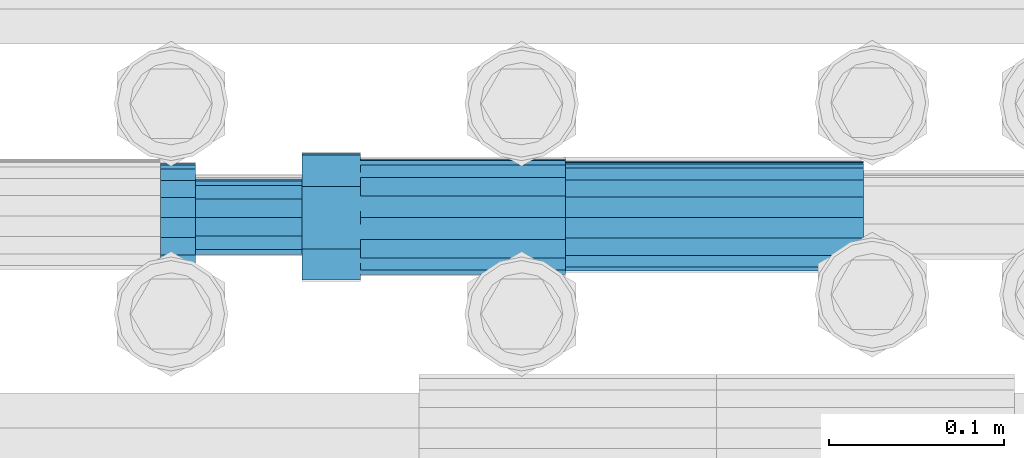
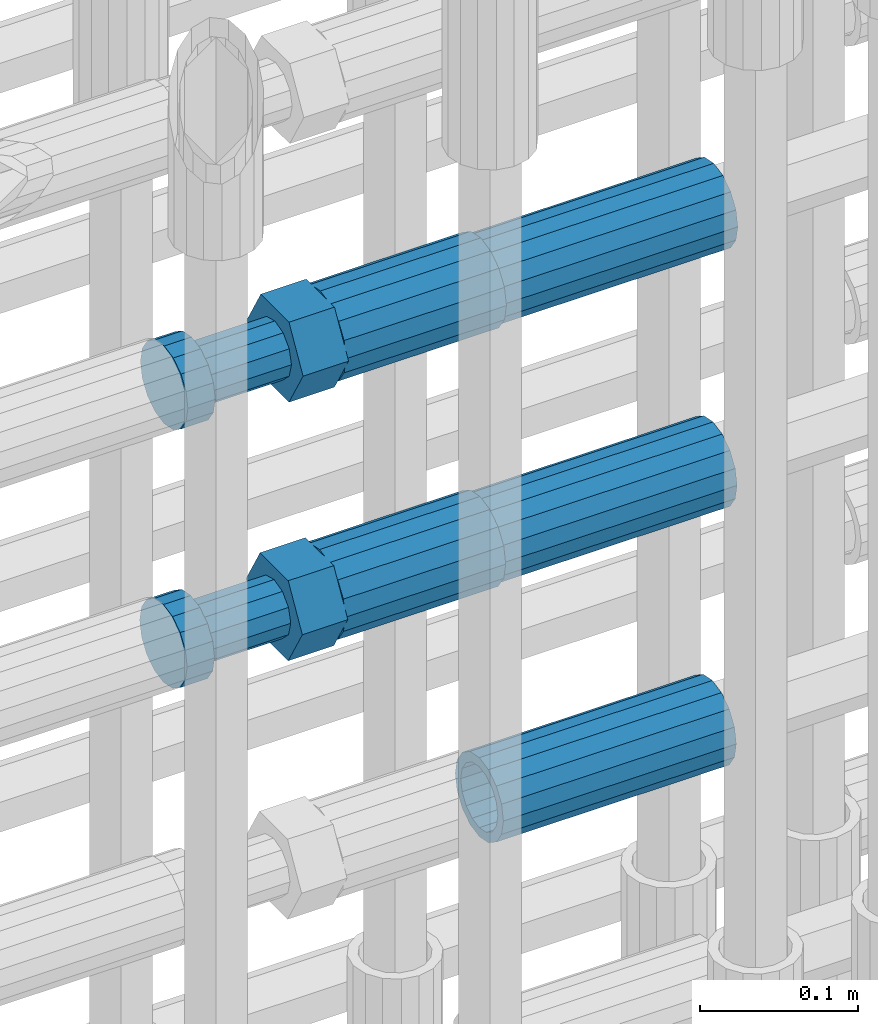
# One storey, part 41 of 119: 5 beams.
"""IFC2X3 building model written with IfcOpenShell, lengths in millimetres."""

from ifc_helpers import new_model, si_unit, frame, origin_with_axes, place, context, subcontext, project, spatial, faceted_brep, material, type_object, element, save


model = new_model("IFC2X3")

# Units and contexts
model_context = context("Model", 3, precision=1e-05, world=origin_with_axes())
body_context = subcontext(model_context, "Body", "Model", "MODEL_VIEW")
ifc_project = project(units=[si_unit("LENGTHUNIT", "METRE", prefix="MILLI"), si_unit("AREAUNIT", "SQUARE_METRE"), si_unit("VOLUMEUNIT", "CUBIC_METRE"), si_unit("MASSUNIT", "GRAM", prefix="KILO"), si_unit("TIMEUNIT", "SECOND"), si_unit("PLANEANGLEUNIT", "RADIAN"), si_unit("SOLIDANGLEUNIT", "STERADIAN"), si_unit("THERMODYNAMICTEMPERATUREUNIT", "DEGREE_CELSIUS"), si_unit("LUMINOUSINTENSITYUNIT", "LUMEN")], contexts=[model_context])

# Site, building, storey
site_placement = place(None, origin_with_axes())
site = spatial("IfcSite", under=ifc_project, at=site_placement, CompositionType="ELEMENT")
building_placement = place(site_placement, origin_with_axes())
building = spatial("IfcBuilding", under=site, at=building_placement, Name="Undefined", CompositionType="ELEMENT")
storey_placement = place(building_placement, origin_with_axes())
storey = spatial("IfcBuildingStorey", under=building, at=storey_placement, Name="Undefined", CompositionType="ELEMENT", Elevation=0.0)

# Beams
ifc_material = material(Name="STEEL/S275")
beam_type_1 = type_object("IfcBeamType", PredefinedType="NOTDEFINED")
beam_1_placement = place(storey_placement, frame((2035519.99345925, 6206280.97777132, 20556.4668409387), z_axis=(0.0, 0.0, 1.0), x_axis=(-0.99999999999998, 1.98000110685822e-07, 0.0)))
element("IfcBeam", 1, at=beam_1_placement, inside=storey, type_object=beam_type_1, material=ifc_material, Name="AG40N", context=body_context, shape_type="Brep", body=[
    faceted_brep([(1.62981450557709e-09, -23.4999999990687, 0.0), (7.45058059692383e-09, -21.7111690142192, 8.99306066057534), (170.000002125278, -21.711168999318, 8.99306066022245), (170.000002127141, -23.4999999844003, -3.66071617463604e-10), (4.65661287307739e-09, -16.6170093587134, 16.6170093578889), (170.000002122484, -16.6170093440451, 16.6170093575288), (1.86264514923096e-09, -8.99306066217832, 21.7111690140277), (170.000002118759, -8.99306064750999, 21.7111690136603), (2.3283064365387e-10, 9.31322574615479e-10, 23.5), (170.000002114102, 1.28056854009628e-08, 23.4999999996485), (-6.51925802230835e-09, 8.99306065868586, 21.7111690140241), (170.00000211224, 8.99306067335419, 21.7111690136639), (-7.45058059692383e-09, 16.6170093561523, 16.6170093578853), (170.000002109446, 16.6170093708206, 16.6170093575324), (-9.31322574615479e-09, 21.711169013055, 8.99306066057534), (170.000002108514, 21.7111690277234, 8.99306066022245), (-1.16415321826935e-09, 23.5000000009313, 0.0), (170.000002108514, 23.5000000144355, -3.66071617463604e-10), (-8.38190317153931e-09, 21.7111690151505, -8.99306066059444), (170.000002110377, 21.7111690300517, -8.9930606609546), (-5.58793544769287e-09, 16.6170093598776, -16.6170093579008), (170.000002113171, 16.6170093745459, -16.6170093582609), (-9.31322574615479e-10, 8.99306066334248, -21.7111690140396), (170.000002115965, 8.99306067801081, -21.7111690143961), (2.3283064365387e-10, 9.31322574615479e-10, -23.5), (170.00000211969, 1.7927959561348e-08, -23.5000000003843), (5.58793544769287e-09, -8.99306065752171, -21.7111690140396), (170.000002123415, -8.99306064285338, -21.7111690143961), (8.38190317153931e-09, -16.6170093549881, -16.6170093579008), (170.000002125278, -16.6170093403198, -16.6170093582646), (9.31322574615479e-09, -21.7111690121237, -8.99306066059444), (170.000002127141, -21.7111689972226, -8.9930606609546), (1.11758708953857e-08, -30.4999999990687, -9.54969436861575e-12), (1.30385160446167e-08, -28.1783257392235, -11.6718446871514), (170.000002129003, -28.1783257243223, -11.6718446875116), (170.000002129935, -30.4999999841675, -3.66071617463604e-10), (1.02445483207703e-08, -21.5667568228673, -21.5667568262129), (170.000002128072, -21.566756808199, -21.5667568265694), (7.45058059692383e-09, -11.6718446831219, -28.1783257416196), (170.000002125278, -11.6718446684536, -28.1783257419834), (3.72529029846191e-09, 3.95812094211578e-09, -30.5000000000277), (170.00000211969, 1.83936208486557e-08, -30.5000000003879), (-9.31322574615479e-10, 11.6718446905725, -28.1783257416232), (170.000002115965, 11.6718447052408, -28.1783257419797), (-6.51925802230835e-09, 21.5667568286881, -21.5667568262093), (170.000002110377, 21.5667568433564, -21.5667568265694), (-9.31322574615479e-09, 28.178325742716, -11.6718446871478), (170.000002108514, 28.1783257573843, -11.6718446875079), (-1.21071934700012e-08, 30.5, -5.91171556152403e-12), (170.000002106652, 30.5000000144355, -3.62433638656512e-10), (-1.21071934700012e-08, 28.1783257401548, 11.6718446871359), (170.00000210572, 28.1783257548232, 11.6718446867794), (-1.02445483207703e-08, 21.5667568240315, 21.5667568261974), (170.000002107583, 21.566756838467, 21.5667568258409), (-7.45058059692383e-09, 11.671844684286, 28.1783257416041), (170.000002110377, 11.6718446989544, 28.178325741244), (-2.79396772384644e-09, -2.56113708019257e-09, 30.5000000000159), (170.000002114102, 1.18743628263474e-08, 30.4999999996558), (1.86264514923096e-09, -11.6718446896411, 28.1783257416114), (170.000002118759, -11.67184467474, 28.178325741244), (7.45058059692383e-09, -21.5667568275239, 21.5667568261974), (170.000002123415, -21.5667568126228, 21.5667568258373), (1.02445483207703e-08, -28.1783257415518, 11.6718446871359), (170.000002127141, -28.1783257271163, 11.6718446867794)], [[[0, 1, 2, 3]], [[1, 4, 5, 2]], [[4, 6, 7, 5]], [[6, 8, 9, 7]], [[8, 10, 11, 9]], [[10, 12, 13, 11]], [[12, 14, 15, 13]], [[14, 16, 17, 15]], [[16, 18, 19, 17]], [[18, 20, 21, 19]], [[20, 22, 23, 21]], [[22, 24, 25, 23]], [[24, 26, 27, 25]], [[26, 28, 29, 27]], [[28, 30, 31, 29]], [[30, 0, 3, 31]], [[32, 33, 34, 35]], [[33, 36, 37, 34]], [[36, 38, 39, 37]], [[38, 40, 41, 39]], [[40, 42, 43, 41]], [[42, 44, 45, 43]], [[44, 46, 47, 45]], [[46, 48, 49, 47]], [[48, 50, 51, 49]], [[50, 52, 53, 51]], [[52, 54, 55, 53]], [[54, 56, 57, 55]], [[56, 58, 59, 57]], [[58, 60, 61, 59]], [[60, 62, 63, 61]], [[62, 32, 35, 63]], [[37, 39, 41, 43, 45, 47, 49, 51, 53, 55, 57, 59, 61, 63, 35, 34], [5, 7, 9, 11, 13, 15, 17, 19, 21, 23, 25, 27, 29, 31, 3, 2]], [[62, 60, 58, 56, 54, 52, 50, 48, 46, 44, 42, 40, 38, 36, 33, 32], [30, 28, 26, 24, 22, 20, 18, 16, 14, 12, 10, 8, 6, 4, 1, 0]]]),
])
beam_2_placement = place(storey_placement, frame((2035519.99345925, 6206281.90777132, 20356.4668409387), z_axis=(0.0, 0.0, 1.0), x_axis=(-0.99999999999998, 1.98000110685822e-07, 0.0)))
element("IfcBeam", 2, at=beam_2_placement, inside=storey, type_object=beam_type_1, material=ifc_material, Name="AG40N", context=body_context, shape_type="Brep", body=[
    faceted_brep([(1.62981450557709e-09, -23.4999999990687, 0.0), (7.45058059692383e-09, -21.7111690142192, 8.99306066057534), (170.000002125278, -21.711168999318, 8.99306066022245), (170.000002127141, -23.4999999844003, -3.66071617463604e-10), (4.65661287307739e-09, -16.6170093587134, 16.6170093578889), (170.000002122484, -16.6170093440451, 16.6170093575288), (1.86264514923096e-09, -8.99306066217832, 21.7111690140277), (170.000002118759, -8.99306064750999, 21.7111690136603), (2.3283064365387e-10, 9.31322574615479e-10, 23.5), (170.000002114102, 1.28056854009628e-08, 23.4999999996485), (-6.51925802230835e-09, 8.99306065868586, 21.7111690140241), (170.00000211224, 8.99306067335419, 21.7111690136639), (-7.45058059692383e-09, 16.6170093561523, 16.6170093578853), (170.000002109446, 16.6170093708206, 16.6170093575324), (-9.31322574615479e-09, 21.711169013055, 8.99306066057534), (170.000002108514, 21.7111690277234, 8.99306066022245), (-1.16415321826935e-09, 23.5000000009313, 0.0), (170.000002108514, 23.5000000144355, -3.66071617463604e-10), (-8.38190317153931e-09, 21.7111690151505, -8.99306066059444), (170.000002110377, 21.7111690300517, -8.9930606609546), (-5.58793544769287e-09, 16.6170093598776, -16.6170093579008), (170.000002113171, 16.6170093745459, -16.6170093582609), (-9.31322574615479e-10, 8.99306066334248, -21.7111690140396), (170.000002115965, 8.99306067801081, -21.7111690143961), (2.3283064365387e-10, 9.31322574615479e-10, -23.5), (170.00000211969, 1.7927959561348e-08, -23.5000000003843), (5.58793544769287e-09, -8.99306065752171, -21.7111690140396), (170.000002123415, -8.99306064285338, -21.7111690143961), (8.38190317153931e-09, -16.6170093549881, -16.6170093579008), (170.000002125278, -16.6170093403198, -16.6170093582646), (9.31322574615479e-09, -21.7111690121237, -8.99306066059444), (170.000002127141, -21.7111689972226, -8.9930606609546), (1.11758708953857e-08, -30.4999999990687, -9.54969436861575e-12), (1.30385160446167e-08, -28.1783257392235, -11.6718446871514), (170.000002129003, -28.1783257243223, -11.6718446875116), (170.000002129935, -30.4999999841675, -3.66071617463604e-10), (1.02445483207703e-08, -21.5667568228673, -21.5667568262129), (170.000002128072, -21.566756808199, -21.5667568265694), (7.45058059692383e-09, -11.6718446831219, -28.1783257416196), (170.000002125278, -11.6718446684536, -28.1783257419834), (3.72529029846191e-09, 3.95812094211578e-09, -30.5000000000277), (170.00000211969, 1.83936208486557e-08, -30.5000000003879), (-9.31322574615479e-10, 11.6718446905725, -28.1783257416232), (170.000002115965, 11.6718447052408, -28.1783257419797), (-6.51925802230835e-09, 21.5667568286881, -21.5667568262093), (170.000002110377, 21.5667568433564, -21.5667568265694), (-9.31322574615479e-09, 28.178325742716, -11.6718446871478), (170.000002108514, 28.1783257573843, -11.6718446875079), (-1.21071934700012e-08, 30.5, -5.91171556152403e-12), (170.000002106652, 30.5000000144355, -3.62433638656512e-10), (-1.21071934700012e-08, 28.1783257401548, 11.6718446871359), (170.00000210572, 28.1783257548232, 11.6718446867794), (-1.02445483207703e-08, 21.5667568240315, 21.5667568261974), (170.000002107583, 21.566756838467, 21.5667568258409), (-7.45058059692383e-09, 11.671844684286, 28.1783257416041), (170.000002110377, 11.6718446989544, 28.178325741244), (-2.79396772384644e-09, -2.56113708019257e-09, 30.5000000000159), (170.000002114102, 1.18743628263474e-08, 30.4999999996558), (1.86264514923096e-09, -11.6718446896411, 28.1783257416114), (170.000002118759, -11.67184467474, 28.178325741244), (7.45058059692383e-09, -21.5667568275239, 21.5667568261974), (170.000002123415, -21.5667568126228, 21.5667568258373), (1.02445483207703e-08, -28.1783257415518, 11.6718446871359), (170.000002127141, -28.1783257271163, 11.6718446867794)], [[[0, 1, 2, 3]], [[1, 4, 5, 2]], [[4, 6, 7, 5]], [[6, 8, 9, 7]], [[8, 10, 11, 9]], [[10, 12, 13, 11]], [[12, 14, 15, 13]], [[14, 16, 17, 15]], [[16, 18, 19, 17]], [[18, 20, 21, 19]], [[20, 22, 23, 21]], [[22, 24, 25, 23]], [[24, 26, 27, 25]], [[26, 28, 29, 27]], [[28, 30, 31, 29]], [[30, 0, 3, 31]], [[32, 33, 34, 35]], [[33, 36, 37, 34]], [[36, 38, 39, 37]], [[38, 40, 41, 39]], [[40, 42, 43, 41]], [[42, 44, 45, 43]], [[44, 46, 47, 45]], [[46, 48, 49, 47]], [[48, 50, 51, 49]], [[50, 52, 53, 51]], [[52, 54, 55, 53]], [[54, 56, 57, 55]], [[56, 58, 59, 57]], [[58, 60, 61, 59]], [[60, 62, 63, 61]], [[62, 32, 35, 63]], [[37, 39, 41, 43, 45, 47, 49, 51, 53, 55, 57, 59, 61, 63, 35, 34], [5, 7, 9, 11, 13, 15, 17, 19, 21, 23, 25, 27, 29, 31, 3, 2]], [[62, 60, 58, 56, 54, 52, 50, 48, 46, 44, 42, 40, 38, 36, 33, 32], [30, 28, 26, 24, 22, 20, 18, 16, 14, 12, 10, 8, 6, 4, 1, 0]]]),
])
beam_3_placement = place(storey_placement, frame((2035519.99345925, 6206282.82777132, 20156.4668409387), z_axis=(0.0, 0.0, 1.0), x_axis=(-0.99999999999998, 1.98000110685822e-07, 0.0)))
element("IfcBeam", 3, at=beam_3_placement, inside=storey, type_object=beam_type_1, material=ifc_material, Name="AG40N", context=body_context, shape_type="Brep", body=[
    faceted_brep([(1.62981450557709e-09, -23.4999999990687, 0.0), (7.45058059692383e-09, -21.7111690142192, 8.99306066057534), (170.000002125278, -21.711168999318, 8.99306066022245), (170.000002127141, -23.4999999844003, -3.66071617463604e-10), (4.65661287307739e-09, -16.6170093587134, 16.6170093578889), (170.000002122484, -16.6170093440451, 16.6170093575288), (1.86264514923096e-09, -8.99306066217832, 21.7111690140277), (170.000002118759, -8.99306064750999, 21.7111690136603), (2.3283064365387e-10, 9.31322574615479e-10, 23.5), (170.000002114102, 1.28056854009628e-08, 23.4999999996485), (-6.51925802230835e-09, 8.99306065868586, 21.7111690140241), (170.00000211224, 8.99306067335419, 21.7111690136639), (-7.45058059692383e-09, 16.6170093561523, 16.6170093578853), (170.000002109446, 16.6170093708206, 16.6170093575324), (-9.31322574615479e-09, 21.711169013055, 8.99306066057534), (170.000002108514, 21.7111690277234, 8.99306066022245), (-1.16415321826935e-09, 23.5000000009313, 0.0), (170.000002108514, 23.5000000144355, -3.66071617463604e-10), (-8.38190317153931e-09, 21.7111690151505, -8.99306066059444), (170.000002110377, 21.7111690300517, -8.9930606609546), (-5.58793544769287e-09, 16.6170093598776, -16.6170093579008), (170.000002113171, 16.6170093745459, -16.6170093582609), (-9.31322574615479e-10, 8.99306066334248, -21.7111690140396), (170.000002115965, 8.99306067801081, -21.7111690143961), (2.3283064365387e-10, 9.31322574615479e-10, -23.5), (170.00000211969, 1.7927959561348e-08, -23.5000000003843), (5.58793544769287e-09, -8.99306065752171, -21.7111690140396), (170.000002123415, -8.99306064285338, -21.7111690143961), (8.38190317153931e-09, -16.6170093549881, -16.6170093579008), (170.000002125278, -16.6170093403198, -16.6170093582646), (9.31322574615479e-09, -21.7111690121237, -8.99306066059444), (170.000002127141, -21.7111689972226, -8.9930606609546), (1.11758708953857e-08, -30.4999999990687, -9.54969436861575e-12), (1.30385160446167e-08, -28.1783257392235, -11.6718446871514), (170.000002129003, -28.1783257243223, -11.6718446875116), (170.000002129935, -30.4999999841675, -3.66071617463604e-10), (1.02445483207703e-08, -21.5667568228673, -21.5667568262129), (170.000002128072, -21.566756808199, -21.5667568265694), (7.45058059692383e-09, -11.6718446831219, -28.1783257416196), (170.000002125278, -11.6718446684536, -28.1783257419834), (3.72529029846191e-09, 3.95812094211578e-09, -30.5000000000277), (170.00000211969, 1.83936208486557e-08, -30.5000000003879), (-9.31322574615479e-10, 11.6718446905725, -28.1783257416232), (170.000002115965, 11.6718447052408, -28.1783257419797), (-6.51925802230835e-09, 21.5667568286881, -21.5667568262093), (170.000002110377, 21.5667568433564, -21.5667568265694), (-9.31322574615479e-09, 28.178325742716, -11.6718446871478), (170.000002108514, 28.1783257573843, -11.6718446875079), (-1.21071934700012e-08, 30.5, -5.91171556152403e-12), (170.000002106652, 30.5000000144355, -3.62433638656512e-10), (-1.21071934700012e-08, 28.1783257401548, 11.6718446871359), (170.00000210572, 28.1783257548232, 11.6718446867794), (-1.02445483207703e-08, 21.5667568240315, 21.5667568261974), (170.000002107583, 21.566756838467, 21.5667568258409), (-7.45058059692383e-09, 11.671844684286, 28.1783257416041), (170.000002110377, 11.6718446989544, 28.178325741244), (-2.79396772384644e-09, -2.56113708019257e-09, 30.5000000000159), (170.000002114102, 1.18743628263474e-08, 30.4999999996558), (1.86264514923096e-09, -11.6718446896411, 28.1783257416114), (170.000002118759, -11.67184467474, 28.178325741244), (7.45058059692383e-09, -21.5667568275239, 21.5667568261974), (170.000002123415, -21.5667568126228, 21.5667568258373), (1.02445483207703e-08, -28.1783257415518, 11.6718446871359), (170.000002127141, -28.1783257271163, 11.6718446867794)], [[[0, 1, 2, 3]], [[1, 4, 5, 2]], [[4, 6, 7, 5]], [[6, 8, 9, 7]], [[8, 10, 11, 9]], [[10, 12, 13, 11]], [[12, 14, 15, 13]], [[14, 16, 17, 15]], [[16, 18, 19, 17]], [[18, 20, 21, 19]], [[20, 22, 23, 21]], [[22, 24, 25, 23]], [[24, 26, 27, 25]], [[26, 28, 29, 27]], [[28, 30, 31, 29]], [[30, 0, 3, 31]], [[32, 33, 34, 35]], [[33, 36, 37, 34]], [[36, 38, 39, 37]], [[38, 40, 41, 39]], [[40, 42, 43, 41]], [[42, 44, 45, 43]], [[44, 46, 47, 45]], [[46, 48, 49, 47]], [[48, 50, 51, 49]], [[50, 52, 53, 51]], [[52, 54, 55, 53]], [[54, 56, 57, 55]], [[56, 58, 59, 57]], [[58, 60, 61, 59]], [[60, 62, 63, 61]], [[62, 32, 35, 63]], [[37, 39, 41, 43, 45, 47, 49, 51, 53, 55, 57, 59, 61, 63, 35, 34], [5, 7, 9, 11, 13, 15, 17, 19, 21, 23, 25, 27, 29, 31, 3, 2]], [[62, 60, 58, 56, 54, 52, 50, 48, 46, 44, 42, 40, 38, 36, 33, 32], [30, 28, 26, 24, 22, 20, 18, 16, 14, 12, 10, 8, 6, 4, 1, 0]]]),
])
beam_type_2 = type_object("IfcBeamType", Name="ROD65", PredefinedType="NOTDEFINED")
beam_4_placement = place(storey_placement, frame((2035349.99345925, 6206280.97777132, 20556.4668409387), z_axis=(0.0, 0.0, 1.0), x_axis=(-0.99999999999998, 1.98000110685822e-07, 0.0)))
element("IfcBeam", 4, at=beam_4_placement, inside=storey, type_object=beam_type_2, material=ifc_material, Name="AGB40", ObjectType="ROD65", context=body_context, shape_type="Brep", body=[
    faceted_brep([(116.999999999069, 17.8249999252148, 30.8738056446964), (116.999999998137, 22.0056957420893, 23.632628078838), (116.999999999069, 12.4372115600854, 30.0260848066173), (116.999999999069, 8.17543111252598, 30.8738056446964), (117.000000000931, -17.8250000746921, 30.8738056446964), (150.200000001118, -17.8250000723638, 30.8738056446964), (150.199999999255, 17.8249999275431, 30.8738056446964), (117.000000000931, -8.17543109622784, 30.8738056446964), (117.000000001863, -22.0056959956419, 23.6326278985034), (117.000000000931, -12.4372115437873, 30.0260848066173), (117.000000001863, -35.6500000746455, -2.18278728425503e-10), (150.200000002049, -35.6500000723172, -2.18278728425503e-10), (117.000000001863, -30.8443149488885, 8.32369080289209), (117.000000001863, -30.8443149488885, -8.32369080355784), (117.000000002794, -32.4999999918509, 0.0), (117.000000000931, -17.8250000746921, -30.873805645133), (150.200000001118, -17.8250000723638, -30.873805645133), (117.000000001863, -22.0056959961075, -23.6326278982269), (117.000000000931, -8.17543109389953, -30.873805645133), (117.000000000931, -12.4372115437873, -30.0260848066173), (116.999999999069, 17.8249999252148, -30.873805645133), (150.199999999255, 17.8249999275431, -30.873805645133), (116.999999999069, 8.17543111019768, -30.873805645133), (116.999999999069, 12.4372115600854, -30.0260848066173), (116.999999998137, 22.005695742555, -23.6326280785652), (116.999999998137, 35.6499999251682, -2.18278728425503e-10), (150.199999998324, 35.6499999277294, -2.18278728425503e-10), (116.999999998137, 30.8443150522653, -8.32369036550881), (116.999999997206, 32.5000000081491, 0.0), (116.999999998137, 30.8443150522653, 8.32369036483942), (1.86264514923096e-09, -22.9809703885112, 22.9809703885621), (1.86264514923096e-09, -30.0260848065373, 12.4372115518672), (117.000000001863, -30.0260847983882, 12.4372115518672), (117.000000001863, -22.9809703803621, 22.9809703885621), (-1.86264514923096e-09, 22.9809703885112, -22.9809703885621), (-1.86264514923096e-09, 30.0260848065373, -12.4372115518672), (116.999999998137, 30.0260848146863, -12.4372115518672), (116.999999998137, 22.9809703966603, -22.9809703885621), (1.86264514923096e-09, -30.0260848065373, -12.4372115518672), (1.86264514923096e-09, -22.9809703885112, -22.9809703885621), (117.000000001863, -22.9809703803621, -22.9809703885621), (117.000000001863, -30.0260847983882, -12.4372115518672), (9.31322574615479e-10, -12.4372115519363, 30.0260848066173), (0.0, 0.0, 32.5), (-9.31322574615479e-10, 12.4372115519363, 30.0260848066173), (-1.86264514923096e-09, 22.9809703885112, 22.9809703885621), (-1.86264514923096e-09, 30.0260848065373, 12.4372115518672), (-2.79396772384644e-09, 32.5, 0.0), (-9.31322574615479e-10, 12.4372115519363, -30.0260848066173), (0.0, 0.0, -32.5), (9.31322574615479e-10, -12.4372115519363, -30.0260848066173), (2.79396772384644e-09, -32.5, 0.0), (116.999999998137, 22.9809703966603, 22.9809703885621), (116.999999998137, 30.0260848146863, 12.4372115518672), (117.0, 8.14907252788544e-09, -32.5), (117.0, 8.14907252788544e-09, 32.5), (150.200000000186, -10.5000000959262, 18.1865334791873), (150.199999999255, -9.59262251853943e-08, 20.9999999997126), (150.199999998324, 10.4999999040738, 18.1865334791873), (150.199999997392, 18.1865333835594, 10.4999999997126), (150.199999997392, 20.9999999040738, -2.87400325760245e-10), (150.199999997392, 18.1865333835594, -10.5000000002874), (150.199999998324, 10.4999999040738, -18.1865334797621), (150.199999999255, -9.59262251853943e-08, -21.0000000002874), (150.200000000186, -10.5000000959262, -18.1865334797621), (150.200000000186, -18.1865335754119, -10.5000000002874), (150.200000001118, -21.0000000959262, -2.87400325760245e-10), (150.200000000186, -18.1865335754119, 10.4999999997126), (210.979999999516, 10.4999999082647, 18.1865334791873), (210.979999999516, -9.17352735996246e-08, 20.9999999997126), (210.979999997653, 18.1865333877504, 10.4999999997126), (210.979999997653, 20.9999999082647, -2.87400325760245e-10), (210.979999997653, 18.1865333877504, -10.5000000002874), (210.979999999516, 10.4999999082647, -18.1865334797621), (210.979999999516, -9.17352735996246e-08, -21.0000000002874), (210.979999999516, -10.5000000917353, -18.1865334797621), (210.980000000447, -18.1865335712209, -10.5000000002874), (210.980000001378, -21.0000000917353, -2.87400325760245e-10), (210.980000000447, -18.1865335712209, 10.4999999997126), (210.979999999516, -10.5000000917353, 18.1865334791873), (211.001368402503, -27.7269939335529, -11.4911163272045), (211.003082515672, -21.2238095656503, -21.2238154190527), (231.002518340945, -21.2131946226582, -21.2132004554769), (231.000804228708, -27.7163789905608, -11.4805013636287), (211.001368415542, -11.4911086384673, -27.7269970399575), (231.000804241747, -11.4804936954752, -27.7163820763781), (210.996487061493, -0.0106066407170147, -30.0106107396168), (230.995922887698, 8.30227509140968e-06, -29.999995776041), (210.98918159306, 11.4698940692469, -27.7269970332745), (230.988617419265, 11.4805090120062, -27.7163820696951), (210.980564201251, 21.2025913291145, -21.2238154067054), (230.980000027455, 21.2132062721066, -21.2132004431296), (210.971946807578, 27.7057702087332, -11.4911163110701), (230.971382633783, 27.7163851517253, -11.4805013474943), (210.964641331695, 29.9893806746695, -0.0106149565435771), (230.9640771579, 29.9999956176616, 7.03221303410828e-09), (210.959759964608, 27.7057637346443, 11.4698863966551), (230.959195790812, 27.7163786776364, 11.4805013602345), (210.958045851439, 21.2025793667417, 21.2025854885032), (230.957481677644, 21.2131943097338, 21.2132004520827), (210.959759951569, 11.4698784395587, 27.705767109408), (230.959195776843, 11.4804933823179, 27.7163820729838), (210.964641305618, -0.0106235581915826, 29.9893808090674), (230.964077131823, -8.61519947648048e-06, 29.9999957726432), (210.971946774051, -11.4911242681555, 27.7057671027251), (230.971382599324, -11.4805093251634, 27.7163820663009), (210.98056416586, -21.2238215280231, 21.2025854761559), (230.979999991134, -21.2132065852638, 21.2132004397354), (210.989181559533, -27.7270004076418, 11.4698863805206), (230.988617384806, -27.7163854646496, 11.4805013441), (210.996487035416, -30.0106108735781, -0.0106149740058754), (230.995922861621, -29.999995930586, -1.04300852399319e-08)], [[[0, 1, 2, 3]], [[4, 5, 6, 0, 3, 7]], [[8, 4, 7, 9]], [[10, 11, 5, 4, 8, 12]], [[13, 10, 12, 14]], [[15, 16, 11, 10, 13, 17]], [[18, 15, 17, 19]], [[20, 21, 16, 15, 18, 22]], [[20, 22, 23, 24]], [[25, 26, 21, 20, 24, 27]], [[25, 27, 28, 29]], [[30, 31, 32, 33]], [[34, 35, 36, 37]], [[38, 39, 40, 41]], [[31, 30, 42, 43, 44, 45, 46, 47, 35, 34, 48, 49, 50, 39, 38, 51]], [[46, 45, 52, 53]], [[28, 47, 46, 53, 29]], [[27, 36, 35, 47, 28]], [[24, 37, 36, 27]], [[23, 48, 34, 37, 24]], [[22, 54, 49, 48, 23]], [[18, 54, 22]], [[19, 50, 49, 54, 18]], [[17, 40, 39, 50, 19]], [[13, 41, 40, 17]], [[14, 51, 38, 41, 13]], [[12, 32, 31, 51, 14]], [[8, 33, 32, 12]], [[9, 42, 30, 33, 8]], [[7, 55, 43, 42, 9]], [[3, 55, 7]], [[2, 44, 43, 55, 3]], [[1, 52, 45, 44, 2]], [[29, 53, 52, 1]], [[0, 6, 26, 25, 29, 1]], [[5, 11, 16, 21, 26, 6], [56, 57, 58, 59, 60, 61, 62, 63, 64, 65, 66, 67]], [[68, 58, 57, 69]], [[70, 59, 58, 68]], [[71, 60, 59, 70]], [[72, 61, 60, 71]], [[73, 62, 61, 72]], [[74, 63, 62, 73]], [[75, 64, 63, 74]], [[76, 65, 64, 75]], [[77, 66, 65, 76]], [[78, 67, 66, 77]], [[79, 56, 67, 78]], [[69, 57, 56, 79]], [[80, 81, 82, 83]], [[81, 84, 85, 82]], [[84, 86, 87, 85]], [[86, 88, 89, 87]], [[88, 90, 91, 89]], [[90, 92, 93, 91]], [[92, 94, 95, 93]], [[94, 96, 97, 95]], [[96, 98, 99, 97]], [[98, 100, 101, 99]], [[100, 102, 103, 101]], [[102, 104, 105, 103]], [[104, 106, 107, 105]], [[106, 108, 109, 107]], [[108, 110, 111, 109]], [[82, 85, 87, 89, 91, 93, 95, 97, 99, 101, 103, 105, 107, 109, 111, 83]], [[110, 80, 83, 111]], [[108, 106, 104, 102, 100, 98, 96, 94, 92, 90, 88, 86, 84, 81, 80, 110], [78, 77, 76, 75, 74, 73, 72, 71, 70, 68, 69, 79]]]),
])
beam_5_placement = place(storey_placement, frame((2035349.99345925, 6206281.90777132, 20356.4668409387), z_axis=(0.0, 0.0, 1.0), x_axis=(-0.99999999999998, 1.98000110685822e-07, 0.0)))
element("IfcBeam", 5, at=beam_5_placement, inside=storey, type_object=beam_type_2, material=ifc_material, Name="AGB40", ObjectType="ROD65", context=body_context, shape_type="Brep", body=[
    faceted_brep([(116.999999999069, 17.8249999252148, 30.8738056446964), (116.999999998137, 22.0056957420893, 23.632628078838), (116.999999999069, 12.4372115600854, 30.0260848066173), (116.999999999069, 8.17543111252598, 30.8738056446964), (117.000000000931, -17.8250000746921, 30.8738056446964), (150.200000001118, -17.8250000723638, 30.8738056446964), (150.199999999255, 17.8249999275431, 30.8738056446964), (117.000000000931, -8.17543109622784, 30.8738056446964), (117.000000001863, -22.0056959956419, 23.6326278985034), (117.000000000931, -12.4372115437873, 30.0260848066173), (117.000000001863, -35.6500000746455, -2.18278728425503e-10), (150.200000002049, -35.6500000723172, -2.18278728425503e-10), (117.000000001863, -30.8443149488885, 8.32369080289209), (117.000000001863, -30.8443149488885, -8.32369080355784), (117.000000002794, -32.4999999918509, 0.0), (117.000000000931, -17.8250000746921, -30.873805645133), (150.200000001118, -17.8250000723638, -30.873805645133), (117.000000001863, -22.0056959961075, -23.6326278982269), (117.000000000931, -8.17543109389953, -30.873805645133), (117.000000000931, -12.4372115437873, -30.0260848066173), (116.999999999069, 17.8249999252148, -30.873805645133), (150.199999999255, 17.8249999275431, -30.873805645133), (116.999999999069, 8.17543111019768, -30.873805645133), (116.999999999069, 12.4372115600854, -30.0260848066173), (116.999999998137, 22.005695742555, -23.6326280785652), (116.999999998137, 35.6499999251682, -2.18278728425503e-10), (150.199999998324, 35.6499999277294, -2.18278728425503e-10), (116.999999998137, 30.8443150522653, -8.32369036550881), (116.999999997206, 32.5000000081491, 0.0), (116.999999998137, 30.8443150522653, 8.32369036483942), (1.86264514923096e-09, -22.9809703885112, 22.9809703885621), (1.86264514923096e-09, -30.0260848065373, 12.4372115518672), (117.000000001863, -30.0260847983882, 12.4372115518672), (117.000000001863, -22.9809703803621, 22.9809703885621), (-1.86264514923096e-09, 22.9809703885112, -22.9809703885621), (-1.86264514923096e-09, 30.0260848065373, -12.4372115518672), (116.999999998137, 30.0260848146863, -12.4372115518672), (116.999999998137, 22.9809703966603, -22.9809703885621), (1.86264514923096e-09, -30.0260848065373, -12.4372115518672), (1.86264514923096e-09, -22.9809703885112, -22.9809703885621), (117.000000001863, -22.9809703803621, -22.9809703885621), (117.000000001863, -30.0260847983882, -12.4372115518672), (9.31322574615479e-10, -12.4372115519363, 30.0260848066173), (0.0, 0.0, 32.5), (-9.31322574615479e-10, 12.4372115519363, 30.0260848066173), (-1.86264514923096e-09, 22.9809703885112, 22.9809703885621), (-1.86264514923096e-09, 30.0260848065373, 12.4372115518672), (-2.79396772384644e-09, 32.5, 0.0), (-9.31322574615479e-10, 12.4372115519363, -30.0260848066173), (0.0, 0.0, -32.5), (9.31322574615479e-10, -12.4372115519363, -30.0260848066173), (2.79396772384644e-09, -32.5, 0.0), (116.999999998137, 22.9809703966603, 22.9809703885621), (116.999999998137, 30.0260848146863, 12.4372115518672), (117.0, 8.14907252788544e-09, -32.5), (117.0, 8.14907252788544e-09, 32.5), (150.200000000186, -10.5000000959262, 18.1865334791873), (150.199999999255, -9.59262251853943e-08, 20.9999999997126), (150.199999998324, 10.4999999040738, 18.1865334791873), (150.199999997392, 18.1865333835594, 10.4999999997126), (150.199999997392, 20.9999999040738, -2.87400325760245e-10), (150.199999997392, 18.1865333835594, -10.5000000002874), (150.199999998324, 10.4999999040738, -18.1865334797621), (150.199999999255, -9.59262251853943e-08, -21.0000000002874), (150.200000000186, -10.5000000959262, -18.1865334797621), (150.200000000186, -18.1865335754119, -10.5000000002874), (150.200000001118, -21.0000000959262, -2.87400325760245e-10), (150.200000000186, -18.1865335754119, 10.4999999997126), (210.979999999516, 10.4999999082647, 18.1865334791873), (210.979999999516, -9.17352735996246e-08, 20.9999999997126), (210.979999997653, 18.1865333877504, 10.4999999997126), (210.979999997653, 20.9999999082647, -2.87400325760245e-10), (210.979999997653, 18.1865333877504, -10.5000000002874), (210.979999999516, 10.4999999082647, -18.1865334797621), (210.979999999516, -9.17352735996246e-08, -21.0000000002874), (210.979999999516, -10.5000000917353, -18.1865334797621), (210.980000000447, -18.1865335712209, -10.5000000002874), (210.980000001378, -21.0000000917353, -2.87400325760245e-10), (210.980000000447, -18.1865335712209, 10.4999999997126), (210.979999999516, -10.5000000917353, 18.1865334791873), (211.001368402503, -27.7269939335529, -11.4911163272045), (211.003082515672, -21.2238095656503, -21.2238154190527), (231.002518340945, -21.2131946226582, -21.2132004554769), (231.000804228708, -27.7163789905608, -11.4805013636287), (211.001368415542, -11.4911086384673, -27.7269970399575), (231.000804241747, -11.4804936954752, -27.7163820763781), (210.996487061493, -0.0106066407170147, -30.0106107396168), (230.995922887698, 8.30227509140968e-06, -29.999995776041), (210.98918159306, 11.4698940692469, -27.7269970332745), (230.988617419265, 11.4805090120062, -27.7163820696951), (210.980564201251, 21.2025913291145, -21.2238154067054), (230.980000027455, 21.2132062721066, -21.2132004431296), (210.971946807578, 27.7057702087332, -11.4911163110701), (230.971382633783, 27.7163851517253, -11.4805013474943), (210.964641331695, 29.9893806746695, -0.0106149565435771), (230.9640771579, 29.9999956176616, 7.03221303410828e-09), (210.959759964608, 27.7057637346443, 11.4698863966551), (230.959195790812, 27.7163786776364, 11.4805013602345), (210.958045851439, 21.2025793667417, 21.2025854885032), (230.957481677644, 21.2131943097338, 21.2132004520827), (210.959759951569, 11.4698784395587, 27.705767109408), (230.959195776843, 11.4804933823179, 27.7163820729838), (210.964641305618, -0.0106235581915826, 29.9893808090674), (230.964077131823, -8.61519947648048e-06, 29.9999957726432), (210.971946774051, -11.4911242681555, 27.7057671027251), (230.971382599324, -11.4805093251634, 27.7163820663009), (210.98056416586, -21.2238215280231, 21.2025854761559), (230.979999991134, -21.2132065852638, 21.2132004397354), (210.989181559533, -27.7270004076418, 11.4698863805206), (230.988617384806, -27.7163854646496, 11.4805013441), (210.996487035416, -30.0106108735781, -0.0106149740058754), (230.995922861621, -29.999995930586, -1.04300852399319e-08)], [[[0, 1, 2, 3]], [[4, 5, 6, 0, 3, 7]], [[8, 4, 7, 9]], [[10, 11, 5, 4, 8, 12]], [[13, 10, 12, 14]], [[15, 16, 11, 10, 13, 17]], [[18, 15, 17, 19]], [[20, 21, 16, 15, 18, 22]], [[20, 22, 23, 24]], [[25, 26, 21, 20, 24, 27]], [[25, 27, 28, 29]], [[30, 31, 32, 33]], [[34, 35, 36, 37]], [[38, 39, 40, 41]], [[31, 30, 42, 43, 44, 45, 46, 47, 35, 34, 48, 49, 50, 39, 38, 51]], [[46, 45, 52, 53]], [[28, 47, 46, 53, 29]], [[27, 36, 35, 47, 28]], [[24, 37, 36, 27]], [[23, 48, 34, 37, 24]], [[22, 54, 49, 48, 23]], [[18, 54, 22]], [[19, 50, 49, 54, 18]], [[17, 40, 39, 50, 19]], [[13, 41, 40, 17]], [[14, 51, 38, 41, 13]], [[12, 32, 31, 51, 14]], [[8, 33, 32, 12]], [[9, 42, 30, 33, 8]], [[7, 55, 43, 42, 9]], [[3, 55, 7]], [[2, 44, 43, 55, 3]], [[1, 52, 45, 44, 2]], [[29, 53, 52, 1]], [[0, 6, 26, 25, 29, 1]], [[5, 11, 16, 21, 26, 6], [56, 57, 58, 59, 60, 61, 62, 63, 64, 65, 66, 67]], [[68, 58, 57, 69]], [[70, 59, 58, 68]], [[71, 60, 59, 70]], [[72, 61, 60, 71]], [[73, 62, 61, 72]], [[74, 63, 62, 73]], [[75, 64, 63, 74]], [[76, 65, 64, 75]], [[77, 66, 65, 76]], [[78, 67, 66, 77]], [[79, 56, 67, 78]], [[69, 57, 56, 79]], [[80, 81, 82, 83]], [[81, 84, 85, 82]], [[84, 86, 87, 85]], [[86, 88, 89, 87]], [[88, 90, 91, 89]], [[90, 92, 93, 91]], [[92, 94, 95, 93]], [[94, 96, 97, 95]], [[96, 98, 99, 97]], [[98, 100, 101, 99]], [[100, 102, 103, 101]], [[102, 104, 105, 103]], [[104, 106, 107, 105]], [[106, 108, 109, 107]], [[108, 110, 111, 109]], [[82, 85, 87, 89, 91, 93, 95, 97, 99, 101, 103, 105, 107, 109, 111, 83]], [[110, 80, 83, 111]], [[108, 106, 104, 102, 100, 98, 96, 94, 92, 90, 88, 86, 84, 81, 80, 110], [78, 77, 76, 75, 74, 73, 72, 71, 70, 68, 69, 79]]]),
])

save(model, "model.ifc")
